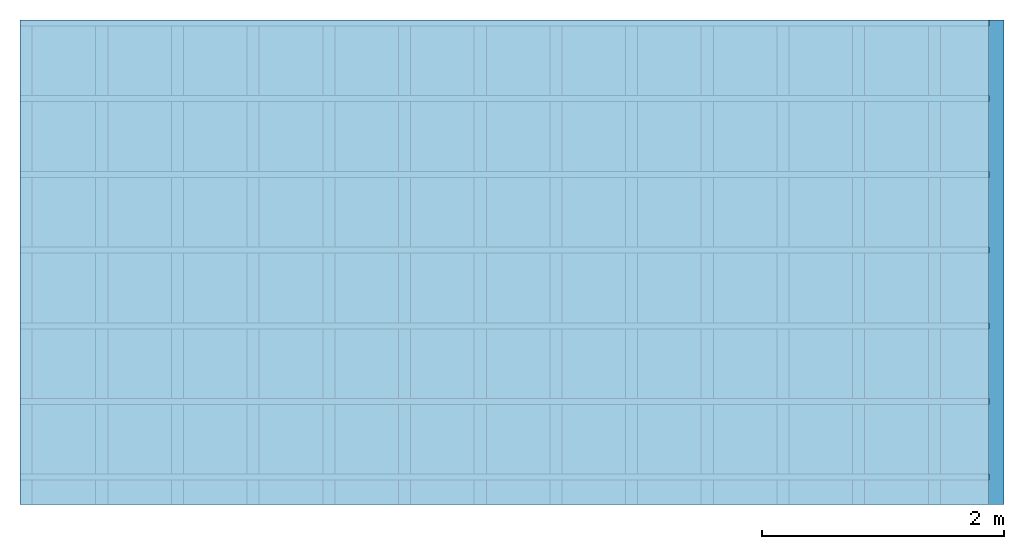
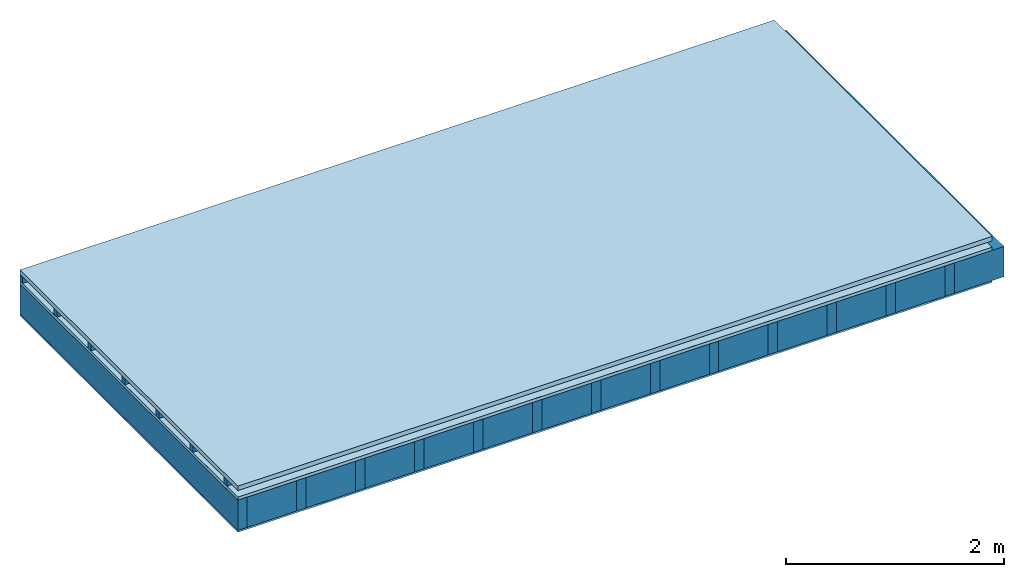
# One storey: 5 plates, 3 members, 1 element without a shape of its own.
"""IFC4 building model written with IfcOpenShell, lengths in metres."""

import ifcopenshell
import ifcopenshell.guid

model = None  # the IFC model being written
_history = None  # IfcOwnerHistory: only IFC2X3 demands one
_inside = {}  # id of a spatial element -> (the spatial element, [elements in it])
_under = {}  # id of a project, library or spatial element -> (it, [spatial elements below it])
_declared = {}  # id of a project -> (the project, [libraries it declares])
_typed = {}  # id of a type object -> (the type object, [elements of that type])
_made_of = {}  # id of a material, layer set ... -> (it, [elements and type objects made of it])


def new_model(schema):
    """Start an empty IFC model of exactly this schema.

    Asked for "IFC4X3", IfcOpenShell would pick the latest addendum, in which some entities
    have other attributes; the version numbers below select the first issue.
    IFC2X3 requires an IfcOwnerHistory on every rooted entity: one is made here for all.
    """
    global model, _history
    if schema == "IFC4X3":
        model = ifcopenshell.file(schema_version=(4, 3, 0, 0))
    else:
        model = ifcopenshell.file(schema=schema)
    _inside.clear()
    _under.clear()
    _declared.clear()
    _typed.clear()
    _made_of.clear()
    _history = None
    if model.schema == "IFC2X3":
        org = make("IfcOrganization", Name="unknown")
        user = make(
            "IfcPersonAndOrganization",
            ThePerson=make("IfcPerson", FamilyName="unknown"),
            TheOrganization=org,
        )
        app = make(
            "IfcApplication",
            ApplicationDeveloper=org,
            Version="unknown",
            ApplicationFullName="unknown",
            ApplicationIdentifier="unknown",
        )
        _history = make(
            "IfcOwnerHistory",
            OwningUser=user,
            OwningApplication=app,
            ChangeAction="ADDED",
            CreationDate=0,
        )
    return model


def make(cls, **values):
    """One entity of the class cls with the attributes given. An attribute that is None is left unset."""
    return model.create_entity(
        cls, **{name: value for name, value in values.items() if value is not None}
    )


def rooted(cls, **values):
    """An entity with a GlobalId (a new one), such as an element, a storey or a relation."""
    return make(cls, GlobalId=ifcopenshell.guid.new(), OwnerHistory=_history, **values)


def si_unit(unit_type, name, prefix=None):
    """IfcSIUnit, for example si_unit("LENGTHUNIT", "METRE", prefix="MILLI")."""
    return make("IfcSIUnit", UnitType=unit_type, Prefix=prefix, Name=name)


def derived_unit(unit_type, elements):
    """IfcDerivedUnit: a product of units, each with its exponent."""
    return make(
        "IfcDerivedUnit",
        Elements=[
            make("IfcDerivedUnitElement", Unit=unit, Exponent=power)
            for unit, power in elements
        ],
        UnitType=unit_type,
    )


def assignment(units):
    """IfcUnitAssignment: the units of a project."""
    return None if units is None else make("IfcUnitAssignment", Units=units)


def point(xyz):
    """IfcCartesianPoint."""
    return None if xyz is None else make("IfcCartesianPoint", Coordinates=xyz)


def direction(xyz):
    """IfcDirection."""
    return None if xyz is None else make("IfcDirection", DirectionRatios=xyz)


def frame(location, z_axis=None, x_axis=None):
    """IfcAxis2Placement3D, a coordinate frame: its origin and axes. An axis left out is left unset."""
    return make(
        "IfcAxis2Placement3D",
        Location=point(location),
        Axis=direction(z_axis),
        RefDirection=direction(x_axis),
    )


def frame_2d(location, x_axis=None):
    """IfcAxis2Placement2D, a coordinate frame in the plane: its origin and x axis."""
    return make(
        "IfcAxis2Placement2D", Location=point(location), RefDirection=direction(x_axis)
    )


def origin():
    """The frame at (0, 0, 0) with its axes left unset."""
    return frame((0.0, 0.0, 0.0))


def origin_with_axes():
    """The frame at (0, 0, 0) with the z axis (0, 0, 1) and the x axis (1, 0, 0) written out."""
    return frame((0.0, 0.0, 0.0), z_axis=(0.0, 0.0, 1.0), x_axis=(1.0, 0.0, 0.0))


def place(relative_to, where):
    """IfcLocalPlacement: puts the frame where relative to a parent placement (None: the world)."""
    return make(
        "IfcLocalPlacement", PlacementRelTo=relative_to, RelativePlacement=where
    )


def context(
    kind, dimensions, precision=None, world=None, true_north=None, identifier=None
):
    """IfcGeometricRepresentationContext, for example the 3D "Model" context."""
    return make(
        "IfcGeometricRepresentationContext",
        ContextIdentifier=identifier,
        ContextType=kind,
        CoordinateSpaceDimension=dimensions,
        Precision=precision,
        WorldCoordinateSystem=world,
        TrueNorth=true_north,
    )


def project(units=None, contexts=None):
    """IfcProject with its units and contexts."""
    return rooted(
        "IfcProject",
        Name="project",
        RepresentationContexts=contexts,
        UnitsInContext=assignment(units),
    )


def spatial(cls, under=None, at=None, **own):
    """A site, building, storey or space (cls), placed at a placement, below another one or the project."""
    s = rooted(cls, ObjectPlacement=at, **own)
    if under is not None:
        _under.setdefault(under.id(), (under, []))[1].append(s)
    return s


def profile(cls, at=None, kind="AREA", **sizes):
    """A parametric profile (cls). Its sizes go by their IFC names, for example OverallWidth=200.0."""
    return make(cls, ProfileType=kind, Position=at, **sizes)


def rectangle(**sizes):
    """IfcRectangleProfileDef."""
    return profile("IfcRectangleProfileDef", **sizes)


def extrude(swept, where, along, depth):
    """IfcExtrudedAreaSolid: the profile swept, set in the frame where, extruded along a direction by depth."""
    return make(
        "IfcExtrudedAreaSolid",
        SweptArea=swept,
        Position=where,
        ExtrudedDirection=direction(along),
        Depth=depth,
    )


def shape(context_of_items, identifier, shape_type, items):
    """IfcShapeRepresentation: the items that make up one representation, for example the "Body"."""
    return make(
        "IfcShapeRepresentation",
        ContextOfItems=context_of_items,
        RepresentationIdentifier=identifier,
        RepresentationType=shape_type,
        Items=items,
    )


def material(Name=None, Category=None):
    """IfcMaterial."""
    return make("IfcMaterial", Name=Name, Category=Category)


def layer(
    of_material, thickness, ventilated=None, Name=None, Category=None, Priority=None
):
    """IfcMaterialLayer: one layer of a wall or slab, of a material (None: an air gap)."""
    return make(
        "IfcMaterialLayer",
        Material=of_material,
        LayerThickness=thickness,
        IsVentilated=ventilated,
        Name=Name,
        Category=Category,
        Priority=Priority,
    )


def layer_set(layers, Name=None):
    """IfcMaterialLayerSet."""
    return make("IfcMaterialLayerSet", MaterialLayers=layers, LayerSetName=Name)


def made_of(thing, what):
    """Note that an element or type object is made of a material, layer set ...; save() writes the relation."""
    if what is not None:
        _made_of.setdefault(what.id(), (what, []))[1].append(thing)
    return thing


def type_object(cls, material=None, **own):
    """A type object (cls), such as IfcWallType, which elements share."""
    return made_of(rooted(cls, **own), material)


def element(
    cls,
    number,
    at=None,
    inside=None,
    cuts=None,
    type_object=None,
    material=None,
    context=None,
    identifier="Body",
    shape_type=None,
    held_by="IfcProductDefinitionShape",
    body=None,
    shapes=None,
    **own,
):
    """One element of the class cls, such as IfcWall. Its Tag is "e" and its number.

    at: its placement. inside: the storey or other place that contains it. cuts: it is an
    opening in that element (IfcRelVoidsElement). A single representation is given by context,
    identifier, shape_type and body (its items); several are given by shapes. held_by: the class
    of the entity that holds the representations. save() writes the other relations.
    """
    e = rooted(cls, Tag="e%d" % number, ObjectPlacement=at, **own)
    if body is not None:
        shapes = [shape(context, identifier, shape_type, body)]
    if shapes is not None:
        e.Representation = make(held_by, Representations=shapes)
    if inside is not None:
        _inside.setdefault(inside.id(), (inside, []))[1].append(e)
    if cuts is not None:
        rooted(
            "IfcRelVoidsElement", RelatingBuildingElement=cuts, RelatedOpeningElement=e
        )
    if type_object is not None:
        _typed.setdefault(type_object.id(), (type_object, []))[1].append(e)
    return made_of(e, material)


def aggregate(whole, parts):
    """IfcRelAggregates: a whole, such as a stair, and the parts it consists of."""
    return rooted("IfcRelAggregates", RelatingObject=whole, RelatedObjects=parts)


def save(model, path):
    """Write the relations noted so far, then the file.

    IfcRelAggregates (storeys below a building ...), IfcRelContainedInSpatialStructure (elements
    in a storey), IfcRelDefinesByType, IfcRelAssociatesMaterial and IfcRelDeclares: one each for
    every whole, place, type object, material and project.
    """
    for whole, parts in _under.values():
        aggregate(whole, parts)
    for where, things in _inside.values():
        rooted(
            "IfcRelContainedInSpatialStructure",
            RelatedElements=things,
            RelatingStructure=where,
        )
    for kind, things in _typed.values():
        rooted("IfcRelDefinesByType", RelatedObjects=things, RelatingType=kind)
    for what, things in _made_of.values():
        rooted("IfcRelAssociatesMaterial", RelatedObjects=things, RelatingMaterial=what)
    for by, libraries in _declared.values():
        rooted("IfcRelDeclares", RelatingContext=by, RelatedDefinitions=libraries)
    model.write(path)


model = new_model("IFC4")

# Units and contexts
plan_context = context("Plan", 3, precision=1e-05, world=origin(), true_north=direction((0.0, 1.0)))
model_context = context("Model", 3, precision=1e-05, world=origin(), true_north=direction((0.0, 1.0)))
ifc_project = project(units=[si_unit("LENGTHUNIT", "METRE"), derived_unit("SOUNDPRESSUREUNIT", [(si_unit("PRESSUREUNIT", "PASCAL", prefix="MICRO"), 0)]), si_unit("ENERGYUNIT", "JOULE", prefix="MEGA"), si_unit("MASSUNIT", "GRAM", prefix="KILO"), derived_unit("THERMALTRANSMITTANCEUNIT", [(si_unit("POWERUNIT", "WATT"), 1), (si_unit("AREAUNIT", "SQUARE_METRE"), -1), (si_unit("THERMODYNAMICTEMPERATUREUNIT", "KELVIN"), -1)]), derived_unit("AREADENSITYUNIT", [(si_unit("MASSUNIT", "GRAM", prefix="KILO"), 1), (si_unit("AREAUNIT", "SQUARE_METRE"), -1)]), derived_unit("USERDEFINED", [(si_unit("ENERGYUNIT", "JOULE", prefix="MEGA"), 1), (si_unit("AREAUNIT", "SQUARE_METRE"), -1)])], contexts=[plan_context, model_context])

# Site, building, storey
site = spatial("IfcSite", under=ifc_project)
building_placement = place(None, origin())
building = spatial("IfcBuilding", under=site, at=building_placement)
storey_placement = place(building_placement, origin())
storey = spatial("IfcBuildingStorey", under=building, at=storey_placement)

# Slab, members, plates
ifc_material_1 = material(Name="Roof tiles", Category="03.015")
ifc_layer_1 = layer(ifc_material_1, 0.05, Name="Roofing")
ifc_layer_2 = layer(None, 0.072, Name="Battens / profiles")
ifc_material_2 = material(Name="Roofing underlay", Category="09.008")
ifc_layer_3 = layer(ifc_material_2, 0.00018, Name="Under the roof")
ifc_material_3 = material(Category="10.009")
ifc_layer_4 = layer(ifc_material_3, 0.035, Name="Sub-floor")
ifc_material_4 = material(Name="of the art")
ifc_layer_5 = layer(ifc_material_4, 0.0, Name="Bond")
ifc_layer_6 = layer(None, 0.34, Name="Supporting structure")
ifc_material_5 = material(Name="Vapor barrier polyethylene (PE)", Category="09.002")
ifc_layer_7 = layer(ifc_material_5, 0.00025, Name="Vapor barrier")
ifc_material_6 = material(Name="3-layer panels", Category="07.001")
ifc_layer_8 = layer(ifc_material_6, 0.019, Name="Covering below 1st layer")
ifc_layer_set = layer_set([ifc_layer_1, ifc_layer_2, ifc_layer_3, ifc_layer_4, ifc_layer_5, ifc_layer_6, ifc_layer_7, ifc_layer_8])
slab_type = type_object("IfcSlabType", Name="E0185", PredefinedType="NOTDEFINED", material=ifc_layer_set)
slab_placement = place(None, frame((0.0, 0.0, 0.0), z_axis=(0.0, 0.0, -1.0), x_axis=(1.0, 0.0, 0.0)))
slab = element("IfcSlab", 1, at=slab_placement, inside=storey, type_object=slab_type, material=ifc_layer_set, Name="Slab #1")
ifc_material_7 = material()
member_1_placement = place(slab_placement, origin())
member_1 = element("IfcMember", 2, at=member_1_placement, material=ifc_material_7, Name="Battens / profiles", context=plan_context, shape_type="SweptSolid", body=[
    extrude(rectangle(XDim=0.05, YDim=0.072, at=frame_2d((0.025, 0.036), x_axis=(1.0, 0.0))), frame((0.0, 0.0, 0.05), z_axis=(1.0, 0.0, 0.0), x_axis=(0.0, 1.0, 0.0)), (0.0, 0.0, 1.0), 8.0),
    extrude(rectangle(XDim=0.05, YDim=0.072, at=frame_2d((0.025, 0.036), x_axis=(1.0, 0.0))), frame((0.0, 0.625, 0.05), z_axis=(1.0, 0.0, 0.0), x_axis=(0.0, 1.0, 0.0)), (0.0, 0.0, 1.0), 8.0),
    extrude(rectangle(XDim=0.05, YDim=0.072, at=frame_2d((0.025, 0.036), x_axis=(1.0, 0.0))), frame((0.0, 1.25, 0.05), z_axis=(1.0, 0.0, 0.0), x_axis=(0.0, 1.0, 0.0)), (0.0, 0.0, 1.0), 8.0),
    extrude(rectangle(XDim=0.05, YDim=0.072, at=frame_2d((0.025, 0.036), x_axis=(1.0, 0.0))), frame((0.0, 1.875, 0.05), z_axis=(1.0, 0.0, 0.0), x_axis=(0.0, 1.0, 0.0)), (0.0, 0.0, 1.0), 8.0),
    extrude(rectangle(XDim=0.05, YDim=0.072, at=frame_2d((0.025, 0.036), x_axis=(1.0, 0.0))), frame((0.0, 2.5, 0.05), z_axis=(1.0, 0.0, 0.0), x_axis=(0.0, 1.0, 0.0)), (0.0, 0.0, 1.0), 8.0),
    extrude(rectangle(XDim=0.05, YDim=0.072, at=frame_2d((0.025, 0.036), x_axis=(1.0, 0.0))), frame((0.0, 3.125, 0.05), z_axis=(1.0, 0.0, 0.0), x_axis=(0.0, 1.0, 0.0)), (0.0, 0.0, 1.0), 8.0),
    extrude(rectangle(XDim=0.05, YDim=0.072, at=frame_2d((0.025, 0.036), x_axis=(1.0, 0.0))), frame((0.0, 3.75, 0.05), z_axis=(1.0, 0.0, 0.0), x_axis=(0.0, 1.0, 0.0)), (0.0, 0.0, 1.0), 8.0),
])
ifc_material_8 = material()
member_2_placement = place(slab_placement, origin())
member_2 = element("IfcMember", 3, at=member_2_placement, material=ifc_material_8, Name="Supporting structure", context=plan_context, shape_type="SweptSolid", body=[
    extrude(rectangle(XDim=0.1, YDim=0.34, at=frame_2d((0.05, 0.17), x_axis=(1.0, 0.0))), frame((0.0, 4.0, 0.15718), z_axis=(0.0, -1.0, 0.0), x_axis=(1.0, 0.0, 0.0)), (0.0, 0.0, 1.0), 4.0),
    extrude(rectangle(XDim=0.1, YDim=0.34, at=frame_2d((0.05, 0.17), x_axis=(1.0, 0.0))), frame((0.625, 4.0, 0.15718), z_axis=(0.0, -1.0, 0.0), x_axis=(1.0, 0.0, 0.0)), (0.0, 0.0, 1.0), 4.0),
    extrude(rectangle(XDim=0.1, YDim=0.34, at=frame_2d((0.05, 0.17), x_axis=(1.0, 0.0))), frame((1.25, 4.0, 0.15718), z_axis=(0.0, -1.0, 0.0), x_axis=(1.0, 0.0, 0.0)), (0.0, 0.0, 1.0), 4.0),
    extrude(rectangle(XDim=0.1, YDim=0.34, at=frame_2d((0.05, 0.17), x_axis=(1.0, 0.0))), frame((1.875, 4.0, 0.15718), z_axis=(0.0, -1.0, 0.0), x_axis=(1.0, 0.0, 0.0)), (0.0, 0.0, 1.0), 4.0),
    extrude(rectangle(XDim=0.1, YDim=0.34, at=frame_2d((0.05, 0.17), x_axis=(1.0, 0.0))), frame((2.5, 4.0, 0.15718), z_axis=(0.0, -1.0, 0.0), x_axis=(1.0, 0.0, 0.0)), (0.0, 0.0, 1.0), 4.0),
    extrude(rectangle(XDim=0.1, YDim=0.34, at=frame_2d((0.05, 0.17), x_axis=(1.0, 0.0))), frame((3.125, 4.0, 0.15718), z_axis=(0.0, -1.0, 0.0), x_axis=(1.0, 0.0, 0.0)), (0.0, 0.0, 1.0), 4.0),
    extrude(rectangle(XDim=0.1, YDim=0.34, at=frame_2d((0.05, 0.17), x_axis=(1.0, 0.0))), frame((3.75, 4.0, 0.15718), z_axis=(0.0, -1.0, 0.0), x_axis=(1.0, 0.0, 0.0)), (0.0, 0.0, 1.0), 4.0),
    extrude(rectangle(XDim=0.1, YDim=0.34, at=frame_2d((0.05, 0.17), x_axis=(1.0, 0.0))), frame((4.375, 4.0, 0.15718), z_axis=(0.0, -1.0, 0.0), x_axis=(1.0, 0.0, 0.0)), (0.0, 0.0, 1.0), 4.0),
    extrude(rectangle(XDim=0.1, YDim=0.34, at=frame_2d((0.05, 0.17), x_axis=(1.0, 0.0))), frame((5.0, 4.0, 0.15718), z_axis=(0.0, -1.0, 0.0), x_axis=(1.0, 0.0, 0.0)), (0.0, 0.0, 1.0), 4.0),
    extrude(rectangle(XDim=0.1, YDim=0.34, at=frame_2d((0.05, 0.17), x_axis=(1.0, 0.0))), frame((5.625, 4.0, 0.15718), z_axis=(0.0, -1.0, 0.0), x_axis=(1.0, 0.0, 0.0)), (0.0, 0.0, 1.0), 4.0),
    extrude(rectangle(XDim=0.1, YDim=0.34, at=frame_2d((0.05, 0.17), x_axis=(1.0, 0.0))), frame((6.25, 4.0, 0.15718), z_axis=(0.0, -1.0, 0.0), x_axis=(1.0, 0.0, 0.0)), (0.0, 0.0, 1.0), 4.0),
    extrude(rectangle(XDim=0.1, YDim=0.34, at=frame_2d((0.05, 0.17), x_axis=(1.0, 0.0))), frame((6.875, 4.0, 0.15718), z_axis=(0.0, -1.0, 0.0), x_axis=(1.0, 0.0, 0.0)), (0.0, 0.0, 1.0), 4.0),
    extrude(rectangle(XDim=0.1, YDim=0.34, at=frame_2d((0.05, 0.17), x_axis=(1.0, 0.0))), frame((7.5, 4.0, 0.15718), z_axis=(0.0, -1.0, 0.0), x_axis=(1.0, 0.0, 0.0)), (0.0, 0.0, 1.0), 4.0),
])
ifc_material_9 = material(Name="Mineral wool")
member_3_placement = place(slab_placement, origin())
member_3 = element("IfcMember", 4, at=member_3_placement, material=ifc_material_9, Name="Cavity", context=plan_context, shape_type="SweptSolid", body=[
    extrude(rectangle(XDim=0.525, YDim=0.34, at=frame_2d((0.2625, 0.17), x_axis=(1.0, 0.0))), frame((0.1, 4.0, 0.15718), z_axis=(0.0, -1.0, 0.0), x_axis=(1.0, 0.0, 0.0)), (0.0, 0.0, 1.0), 4.0),
    extrude(rectangle(XDim=0.525, YDim=0.34, at=frame_2d((0.2625, 0.17), x_axis=(1.0, 0.0))), frame((0.725, 4.0, 0.15718), z_axis=(0.0, -1.0, 0.0), x_axis=(1.0, 0.0, 0.0)), (0.0, 0.0, 1.0), 4.0),
    extrude(rectangle(XDim=0.525, YDim=0.34, at=frame_2d((0.2625, 0.17), x_axis=(1.0, 0.0))), frame((1.35, 4.0, 0.15718), z_axis=(0.0, -1.0, 0.0), x_axis=(1.0, 0.0, 0.0)), (0.0, 0.0, 1.0), 4.0),
    extrude(rectangle(XDim=0.525, YDim=0.34, at=frame_2d((0.2625, 0.17), x_axis=(1.0, 0.0))), frame((1.975, 4.0, 0.15718), z_axis=(0.0, -1.0, 0.0), x_axis=(1.0, 0.0, 0.0)), (0.0, 0.0, 1.0), 4.0),
    extrude(rectangle(XDim=0.525, YDim=0.34, at=frame_2d((0.2625, 0.17), x_axis=(1.0, 0.0))), frame((2.6, 4.0, 0.15718), z_axis=(0.0, -1.0, 0.0), x_axis=(1.0, 0.0, 0.0)), (0.0, 0.0, 1.0), 4.0),
    extrude(rectangle(XDim=0.525, YDim=0.34, at=frame_2d((0.2625, 0.17), x_axis=(1.0, 0.0))), frame((3.225, 4.0, 0.15718), z_axis=(0.0, -1.0, 0.0), x_axis=(1.0, 0.0, 0.0)), (0.0, 0.0, 1.0), 4.0),
    extrude(rectangle(XDim=0.525, YDim=0.34, at=frame_2d((0.2625, 0.17), x_axis=(1.0, 0.0))), frame((3.85, 4.0, 0.15718), z_axis=(0.0, -1.0, 0.0), x_axis=(1.0, 0.0, 0.0)), (0.0, 0.0, 1.0), 4.0),
    extrude(rectangle(XDim=0.525, YDim=0.34, at=frame_2d((0.2625, 0.17), x_axis=(1.0, 0.0))), frame((4.475, 4.0, 0.15718), z_axis=(0.0, -1.0, 0.0), x_axis=(1.0, 0.0, 0.0)), (0.0, 0.0, 1.0), 4.0),
    extrude(rectangle(XDim=0.525, YDim=0.34, at=frame_2d((0.2625, 0.17), x_axis=(1.0, 0.0))), frame((5.1, 4.0, 0.15718), z_axis=(0.0, -1.0, 0.0), x_axis=(1.0, 0.0, 0.0)), (0.0, 0.0, 1.0), 4.0),
    extrude(rectangle(XDim=0.525, YDim=0.34, at=frame_2d((0.2625, 0.17), x_axis=(1.0, 0.0))), frame((5.725, 4.0, 0.15718), z_axis=(0.0, -1.0, 0.0), x_axis=(1.0, 0.0, 0.0)), (0.0, 0.0, 1.0), 4.0),
    extrude(rectangle(XDim=0.525, YDim=0.34, at=frame_2d((0.2625, 0.17), x_axis=(1.0, 0.0))), frame((6.35, 4.0, 0.15718), z_axis=(0.0, -1.0, 0.0), x_axis=(1.0, 0.0, 0.0)), (0.0, 0.0, 1.0), 4.0),
    extrude(rectangle(XDim=0.525, YDim=0.34, at=frame_2d((0.2625, 0.17), x_axis=(1.0, 0.0))), frame((6.975, 4.0, 0.15718), z_axis=(0.0, -1.0, 0.0), x_axis=(1.0, 0.0, 0.0)), (0.0, 0.0, 1.0), 4.0),
    extrude(rectangle(XDim=0.525, YDim=0.34, at=frame_2d((0.2625, 0.17), x_axis=(1.0, 0.0))), frame((7.6, 4.0, 0.15718), z_axis=(0.0, -1.0, 0.0), x_axis=(1.0, 0.0, 0.0)), (0.0, 0.0, 1.0), 4.0),
])
plate_1_placement = place(slab_placement, origin())
plate_1 = element("IfcPlate", 5, at=plate_1_placement, material=ifc_material_1, Name="Roofing", context=plan_context, shape_type="SweptSolid", body=[
    extrude(rectangle(XDim=8.0, YDim=4.0, at=frame_2d((4.0, 2.0), x_axis=(1.0, 0.0))), origin_with_axes(), (0.0, 0.0, 1.0), 0.05),
])
plate_2_placement = place(slab_placement, origin())
plate_2 = element("IfcPlate", 6, at=plate_2_placement, material=ifc_material_2, Name="Under the roof", context=plan_context, shape_type="SweptSolid", body=[
    extrude(rectangle(XDim=8.0, YDim=4.0, at=frame_2d((4.0, 2.0), x_axis=(1.0, 0.0))), frame((0.0, 0.0, 0.122), z_axis=(0.0, 0.0, 1.0), x_axis=(1.0, 0.0, 0.0)), (0.0, 0.0, 1.0), 0.00018),
])
plate_3_placement = place(slab_placement, origin())
plate_3 = element("IfcPlate", 7, at=plate_3_placement, material=ifc_material_3, Name="Sub-floor", context=plan_context, shape_type="SweptSolid", body=[
    extrude(rectangle(XDim=8.0, YDim=4.0, at=frame_2d((4.0, 2.0), x_axis=(1.0, 0.0))), frame((0.0, 0.0, 0.12218), z_axis=(0.0, 0.0, 1.0), x_axis=(1.0, 0.0, 0.0)), (0.0, 0.0, 1.0), 0.035),
])
plate_4_placement = place(slab_placement, origin())
plate_4 = element("IfcPlate", 8, at=plate_4_placement, material=ifc_material_5, Name="Vapor barrier", context=plan_context, shape_type="SweptSolid", body=[
    extrude(rectangle(XDim=8.0, YDim=4.0, at=frame_2d((4.0, 2.0), x_axis=(1.0, 0.0))), frame((0.0, 0.0, 0.49718), z_axis=(0.0, 0.0, 1.0), x_axis=(1.0, 0.0, 0.0)), (0.0, 0.0, 1.0), 0.00025),
])
plate_5_placement = place(slab_placement, origin())
plate_5 = element("IfcPlate", 9, at=plate_5_placement, material=ifc_material_6, Name="Covering below 1st layer", context=plan_context, shape_type="SweptSolid", body=[
    extrude(rectangle(XDim=8.0, YDim=4.0, at=frame_2d((4.0, 2.0), x_axis=(1.0, 0.0))), frame((0.0, 0.0, 0.49743), z_axis=(0.0, 0.0, 1.0), x_axis=(1.0, 0.0, 0.0)), (0.0, 0.0, 1.0), 0.019),
])
aggregate(slab, [plate_1, member_1, plate_2, plate_3, member_2, member_3, plate_4, plate_5])

save(model, "model.ifc")
